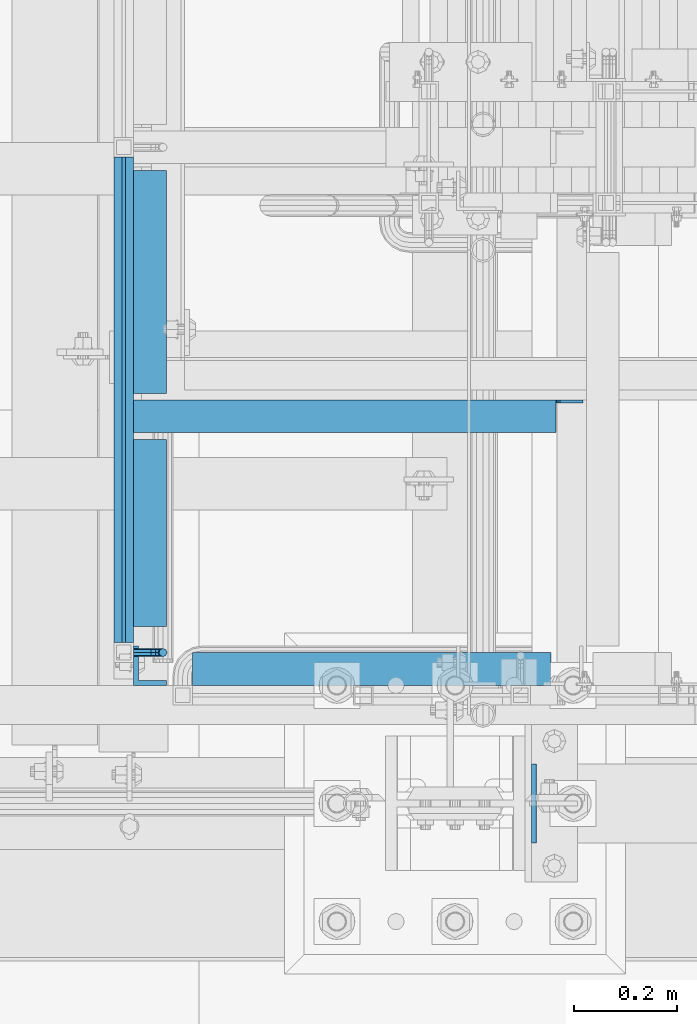
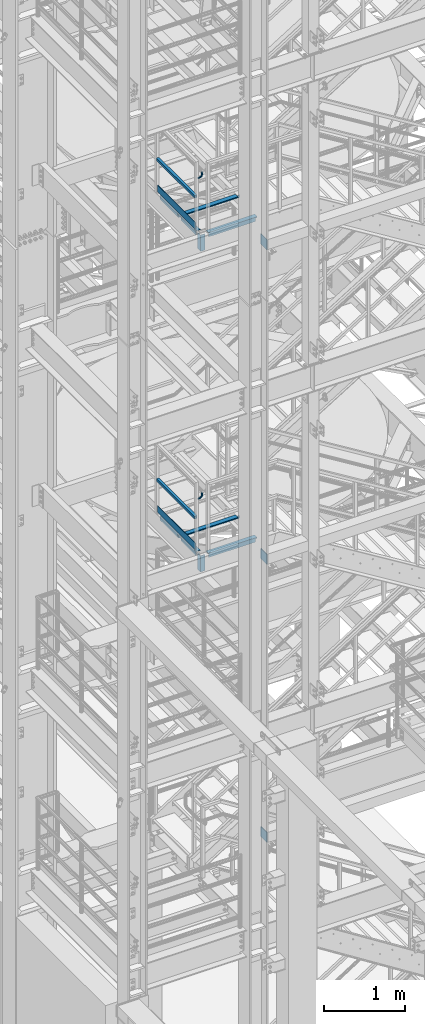
# One storey, part 1125 of 1876: 19 beams, 9 elements without a shape of their own.
"""IFC2X3 building model written with IfcOpenShell, lengths in millimetres."""

from ifc_helpers import new_model, si_unit, frame, origin_with_axes, place, context, subcontext, project, spatial, faceted_brep, material, type_object, element, aggregate, save


model = new_model("IFC2X3")

# Units and contexts
model_context = context("Model", 3, precision=1e-05, world=origin_with_axes())
body_context = subcontext(model_context, "Body", "Model", "MODEL_VIEW")
ifc_project = project(units=[si_unit("LENGTHUNIT", "METRE", prefix="MILLI"), si_unit("AREAUNIT", "SQUARE_METRE"), si_unit("VOLUMEUNIT", "CUBIC_METRE"), si_unit("MASSUNIT", "GRAM", prefix="KILO"), si_unit("TIMEUNIT", "SECOND"), si_unit("PLANEANGLEUNIT", "RADIAN"), si_unit("SOLIDANGLEUNIT", "STERADIAN"), si_unit("THERMODYNAMICTEMPERATUREUNIT", "DEGREE_CELSIUS"), si_unit("LUMINOUSINTENSITYUNIT", "LUMEN")], contexts=[model_context])

# Site, building, storey
site_placement = place(None, origin_with_axes())
site = spatial("IfcSite", under=ifc_project, at=site_placement, CompositionType="ELEMENT")
building_placement = place(site_placement, origin_with_axes())
building = spatial("IfcBuilding", under=site, at=building_placement, Name="Undefined", CompositionType="ELEMENT")
storey_placement = place(building_placement, origin_with_axes())
storey = spatial("IfcBuildingStorey", under=building, at=storey_placement, Name="Undefined", CompositionType="ELEMENT", Elevation=0.0)

# Assembly, beam
assembly_1_placement = place(storey_placement, origin_with_axes())
assembly_1 = element("IfcElementAssembly", 1, at=assembly_1_placement, inside=storey, Name="FRAME", AssemblyPlace="NOTDEFINED", PredefinedType="RIGID_FRAME")
ifc_material_1 = material(Name="STEEL/A36")
beam_type_1 = type_object("IfcBeamType", PredefinedType="NOTDEFINED")
beam_1_placement = place(assembly_1_placement, frame((1879.58075726968, -7188.2, 6407.15001063848), z_axis=(0.0, 0.0, 1.0), x_axis=(0.0, 1.0, 0.0)))
beam_1 = element("IfcBeam", 2, at=beam_1_placement, type_object=beam_type_1, material=ifc_material_1, Name="PLATE", context=body_context, shape_type="Brep", body=[
    faceted_brep([(0.0, 4.76249999999982, -76.1999999999998), (3.63797880709171e-12, 4.76249999999982, 76.1999969482422), (152.399993896484, 4.76250000000073, 76.1999969482422), (152.4, 4.76249999999982, -76.1999999999998), (3.63797880709171e-12, -4.76249999999982, 76.1999969482422), (152.399993896484, -4.76250000000073, 76.1999969482422), (0.0, -4.76249999999982, -76.1999999999998), (152.4, -4.76249999999982, -76.1999999999998)], [[[0, 1, 2, 3]], [[4, 5, 2, 1]], [[4, 6, 7, 5]], [[6, 0, 3, 7]], [[5, 7, 3, 2]], [[6, 4, 1, 0]]]),
])
aggregate(assembly_1, [beam_1])

assembly_2_placement = place(storey_placement, origin_with_axes())
assembly_2 = element("IfcElementAssembly", 3, at=assembly_2_placement, inside=storey, Name="FRAME", AssemblyPlace="NOTDEFINED", PredefinedType="RIGID_FRAME")
beam_2_placement = place(assembly_2_placement, frame((1879.59999980926, -7188.2, 10598.15), z_axis=(0.0, 0.0, 1.0), x_axis=(0.0, 1.0, 0.0)))
beam_2 = element("IfcBeam", 4, at=beam_2_placement, type_object=beam_type_1, material=ifc_material_1, Name="PLATE", context=body_context, shape_type="Brep", body=[
    faceted_brep([(0.0, 4.76249999999982, -76.1999999999998), (3.63797880709171e-12, 4.76249999999982, 76.1999969482422), (152.399993896484, 4.76250000000073, 76.1999969482422), (152.4, 4.76249999999982, -76.1999999999998), (3.63797880709171e-12, -4.76249999999982, 76.1999969482422), (152.399993896484, -4.76250000000073, 76.1999969482422), (0.0, -4.76249999999982, -76.1999999999998), (152.4, -4.76249999999982, -76.1999999999998)], [[[0, 1, 2, 3]], [[4, 5, 2, 1]], [[4, 6, 7, 5]], [[6, 0, 3, 7]], [[5, 7, 3, 2]], [[6, 4, 1, 0]]]),
])
aggregate(assembly_2, [beam_2])

assembly_3_placement = place(storey_placement, origin_with_axes())
assembly_3 = element("IfcElementAssembly", 5, at=assembly_3_placement, inside=storey, Name="FRAME", AssemblyPlace="NOTDEFINED", PredefinedType="RIGID_FRAME")
beam_3_placement = place(assembly_3_placement, frame((1879.59999980926, -7188.2, 15335.25), z_axis=(0.0, 0.0, 1.0), x_axis=(0.0, 1.0, 0.0)))
beam_3 = element("IfcBeam", 6, at=beam_3_placement, type_object=beam_type_1, material=ifc_material_1, Name="PLATE", context=body_context, shape_type="Brep", body=[
    faceted_brep([(0.0, 4.76249999999982, -76.1999999999998), (3.63797880709171e-12, 4.76249999999982, 76.1999969482422), (152.399993896484, 4.76250000000073, 76.1999969482422), (152.4, 4.76249999999982, -76.1999999999998), (3.63797880709171e-12, -4.76249999999982, 76.1999969482422), (152.399993896484, -4.76250000000073, 76.1999969482422), (0.0, -4.76249999999982, -76.1999999999998), (152.4, -4.76249999999982, -76.1999999999998)], [[[0, 1, 2, 3]], [[4, 5, 2, 1]], [[4, 6, 7, 5]], [[6, 0, 3, 7]], [[5, 7, 3, 2]], [[6, 4, 1, 0]]]),
])
aggregate(assembly_3, [beam_3])

# Assembly, beams
assembly_4_placement = place(storey_placement, origin_with_axes())
assembly_4 = element("IfcElementAssembly", 7, at=assembly_4_placement, inside=storey, Name="STRINGER", AssemblyPlace="NOTDEFINED", PredefinedType="RIGID_FRAME")
beam_type_2 = type_object("IfcBeamType", Name="L2-1/2X2-1/2X1/4", PredefinedType="NOTDEFINED")
beam_4_placement = place(assembly_4_placement, frame((1136.64999924824, -6769.10000137764, 15531.2768517499), z_axis=(1.0, 0.0, 0.0), x_axis=(0.0, 1.0, 0.0)))
beam_4 = element("IfcBeam", 8, at=beam_4_placement, type_object=beam_type_2, material=ifc_material_1, Name="ANGLE", ObjectType="L2-1/2X2-1/2X1/4", context=body_context, shape_type="Brep", body=[
    faceted_brep([(0.0, 31.75, -31.75), (0.0, 31.75, 31.75), (361.950002661927, 31.75, 31.7499999999923), (361.950002661926, 31.75, -31.7500000000077), (0.0, 25.3999999999996, 31.75), (361.950002661927, 25.3999999999996, 31.7499999999923), (0.0, 25.3999999999996, -25.3999999999996), (361.950002661926, 25.3999999999996, -25.4000000000076), (0.0, -31.75, -25.3999999999996), (361.950002661926, -31.75, -25.4000000000076), (0.0, -31.75, -31.75), (361.950002661926, -31.75, -31.7500000000077)], [[[0, 1, 2, 3]], [[1, 4, 5, 2]], [[4, 6, 7, 5]], [[6, 8, 9, 7]], [[8, 10, 11, 9]], [[10, 0, 3, 11]], [[5, 7, 9, 11, 3, 2]], [[10, 8, 6, 4, 1, 0]]]),
])
beam_5_placement = place(assembly_4_placement, frame((1136.65000017996, -6318.25000169504, 15531.2768517499), z_axis=(1.0, 0.0, 0.0), x_axis=(0.0, 1.0, 0.0)))
beam_5 = element("IfcBeam", 9, at=beam_5_placement, type_object=beam_type_2, material=ifc_material_1, Name="ANGLE", ObjectType="L2-1/2X2-1/2X1/4", context=body_context, shape_type="Brep", body=[
    faceted_brep([(0.0, 31.75, -31.75), (0.0, 31.75, 31.75), (431.800000762049, 31.75, 31.75), (431.800000762049, 31.75, -31.75), (0.0, 25.3999999999996, 31.75), (431.800000762049, 25.3999999999996, 31.75), (0.0, 25.3999999999996, -25.3999999999996), (431.800000762049, 25.3999999999996, -25.4000000000001), (0.0, -31.75, -25.3999999999996), (431.800000762049, -31.75, -25.4000000000001), (0.0, -31.75, -31.75), (431.800000762049, -31.75, -31.75)], [[[0, 1, 2, 3]], [[1, 4, 5, 2]], [[4, 6, 7, 5]], [[6, 8, 9, 7]], [[8, 10, 11, 9]], [[10, 0, 3, 11]], [[5, 7, 9, 11, 3, 2]], [[10, 8, 6, 4, 1, 0]]]),
])

assembly_5_placement = place(storey_placement, origin_with_axes())
assembly_5 = element("IfcElementAssembly", 10, at=assembly_5_placement, inside=storey, Name="STRINGER", AssemblyPlace="NOTDEFINED", PredefinedType="RIGID_FRAME")
beam_6_placement = place(assembly_5_placement, frame((1136.64999959676, -6769.10000137713, 10702.925), z_axis=(1.0, 0.0, 0.0), x_axis=(0.0, 1.0, 0.0)))
beam_6 = element("IfcBeam", 11, at=beam_6_placement, type_object=beam_type_2, material=ifc_material_1, Name="ANGLE", ObjectType="L2-1/2X2-1/2X1/4", context=body_context, shape_type="Brep", body=[
    faceted_brep([(0.0, 31.75, -31.75), (0.0, 31.75, 31.75), (361.950002661927, 31.75, 31.7499999999923), (361.950002661926, 31.75, -31.7500000000077), (0.0, 25.3999999999996, 31.75), (361.950002661927, 25.3999999999996, 31.7499999999923), (0.0, 25.3999999999996, -25.3999999999996), (361.950002661926, 25.3999999999996, -25.4000000000076), (0.0, -31.75, -25.3999999999996), (361.950002661926, -31.75, -25.4000000000076), (0.0, -31.75, -31.75), (361.950002661926, -31.75, -31.7500000000077)], [[[0, 1, 2, 3]], [[1, 4, 5, 2]], [[4, 6, 7, 5]], [[6, 8, 9, 7]], [[8, 10, 11, 9]], [[10, 0, 3, 11]], [[5, 7, 9, 11, 3, 2]], [[10, 8, 6, 4, 1, 0]]]),
])
beam_7_placement = place(assembly_5_placement, frame((1136.65000052848, -6318.25000169453, 10702.925), z_axis=(1.0, 0.0, 0.0), x_axis=(0.0, 1.0, 0.0)))
beam_7 = element("IfcBeam", 12, at=beam_7_placement, type_object=beam_type_2, material=ifc_material_1, Name="ANGLE", ObjectType="L2-1/2X2-1/2X1/4", context=body_context, shape_type="Brep", body=[
    faceted_brep([(0.0, 31.75, -31.75), (0.0, 31.75, 31.75), (431.800000762049, 31.75, 31.75), (431.800000762049, 31.75, -31.75), (0.0, 25.3999999999996, 31.75), (431.800000762049, 25.3999999999996, 31.75), (0.0, 25.3999999999996, -25.3999999999996), (431.800000762049, 25.3999999999996, -25.4000000000001), (0.0, -31.75, -25.3999999999996), (431.800000762049, -31.75, -25.4000000000001), (0.0, -31.75, -31.75), (431.800000762049, -31.75, -31.75)], [[[0, 1, 2, 3]], [[1, 4, 5, 2]], [[4, 6, 7, 5]], [[6, 8, 9, 7]], [[8, 10, 11, 9]], [[10, 0, 3, 11]], [[5, 7, 9, 11, 3, 2]], [[10, 8, 6, 4, 1, 0]]]),
])

# Beam
beam_8_placement = place(assembly_4_placement, frame((1104.89999999374, -6362.70000114803, 15531.3367795925), z_axis=(0.0, -1.0, 0.0), x_axis=(1.0, 0.0, 0.0)))
beam_8 = element("IfcBeam", 13, at=beam_8_placement, type_object=beam_type_2, material=ifc_material_1, Name="STRINGER", ObjectType="L2-1/2X2-1/2X1/4", context=body_context, shape_type="Brep", body=[
    faceted_brep([(0.0, -31.75, -31.75), (0.0, -31.75, -25.3999999999996), (0.0, 25.3999999999996, -25.3999999999996), (0.0, 25.3999999999996, 31.75), (0.0, 31.75, 31.75), (0.0, 31.75, -31.75), (869.950004852295, 6.34999909336329, -25.3999999999996), (830.262999809266, 6.34999909336329, -25.3999999999996), (825.40292029122, 7.31672901595084, -25.3999999999996), (821.282743823066, 10.0697429164284, -25.3999999999996), (818.529729922588, 14.189919384582, -25.3999999999996), (817.563000000001, 19.0499989026284, -25.3999999999996), (817.563000000001, 25.3999999999996, -25.3999999999996), (869.949999999999, -31.75, -25.3999999999996), (869.950004852295, -19.0499986178183, -25.3999999999996), (817.563000000001, 25.3999999999996, 31.75), (817.563000000001, 31.75, 31.75), (817.563000000001, 31.75, -31.75), (817.563000000001, 19.0499989026284, -31.75), (818.529729922588, 14.189919384582, -31.75), (821.282743823066, 10.0697429164284, -31.75), (825.40292029122, 7.31672901595084, -31.75), (830.262999809266, 6.34999909336329, -31.75), (869.950004852295, 6.34999909336329, -31.75), (869.950004852295, -19.0499986178183, -31.75), (869.949999999999, -31.75, -31.75)], [[[0, 1, 2, 3, 4, 5]], [[6, 7, 8, 9, 10, 11, 12, 2, 1, 13, 14]], [[3, 2, 12, 15]], [[4, 3, 15, 16]], [[5, 4, 16, 17]], [[15, 12, 11, 18, 17, 16]], [[10, 19, 18, 11]], [[9, 20, 19, 10]], [[8, 21, 20, 9]], [[7, 22, 21, 8]], [[6, 23, 22, 7]], [[14, 24, 23, 6]], [[0, 5, 17, 18, 19, 20, 21, 22, 23, 24, 25]], [[1, 0, 25, 13]], [[24, 14, 13, 25]]]),
])

aggregate(assembly_4, [beam_4, beam_5, beam_8])

# Assembly, beam
assembly_6_placement = place(storey_placement, origin_with_axes())
assembly_6 = element("IfcElementAssembly", 14, at=assembly_6_placement, inside=storey, Name="STRINGER", AssemblyPlace="NOTDEFINED", PredefinedType="RIGID_FRAME")
beam_9_placement = place(assembly_6_placement, frame((1995.4875, -6851.65000114876, 15531.2768518519), z_axis=(0.0, 1.0, 0.0), x_axis=(-1.0, 0.0, 0.0)))
beam_9 = element("IfcBeam", 15, at=beam_9_placement, type_object=beam_type_2, material=ifc_material_1, Name="ANGLE", ObjectType="L2-1/2X2-1/2X1/4", context=body_context, shape_type="Brep", body=[
    faceted_brep([(82.5500000000022, 19.0499999999556, -25.3999999999996), (82.5500000000022, 19.0499996253002, -31.75), (107.950000724835, 19.0499996252966, -31.75), (107.950000724835, 19.049999999952, -25.3999999999996), (107.950000724835, -31.7499992371049, -25.3999999999996), (107.950000724835, -31.75, -31.75), (82.5500000000022, 25.3999999999996, 31.75), (82.5500000000022, 25.3999999999996, -25.3999999999996), (776.287500000002, 25.3999999999996, -25.3999999999996), (776.287500000002, 25.3999999999996, 31.75), (82.5500000000022, 31.75, 31.75), (776.287500000002, 31.75, 31.75), (82.5500000000022, 31.75, -31.75), (776.287500000002, 31.75, -31.75), (776.287500000002, -31.75, -25.3999999999996), (776.287500000002, -31.75, -31.75)], [[[0, 1, 2, 3]], [[4, 3, 2, 5]], [[6, 7, 8, 9]], [[10, 6, 9, 11]], [[12, 10, 11, 13]], [[9, 8, 14, 15, 13, 11]], [[15, 14, 4, 5]], [[1, 12, 13, 15, 5, 2]], [[7, 6, 10, 12, 1, 0]], [[14, 8, 7, 0, 3, 4]]]),
])

# Beam
beam_10_placement = place(assembly_5_placement, frame((1104.90000034225, -6362.70000114753, 10702.9250004311), z_axis=(0.0, -1.0, 0.0), x_axis=(1.0, 0.0, 0.0)))
beam_10 = element("IfcBeam", 16, at=beam_10_placement, type_object=beam_type_2, material=ifc_material_1, Name="STRINGER", ObjectType="L2-1/2X2-1/2X1/4", context=body_context, shape_type="Brep", body=[
    faceted_brep([(0.0, -31.75, -31.75), (0.0, -31.75, -25.3999999999996), (0.0, 25.3999999999996, -25.3999999999996), (0.0, 25.3999999999996, 31.75), (0.0, 31.75, 31.75), (0.0, 31.75, -31.75), (869.950004852295, 6.34999909336329, -25.3999999999996), (830.262999809266, 6.34999909336329, -25.3999999999996), (825.40292029122, 7.31672901595084, -25.3999999999996), (821.282743823066, 10.0697429164284, -25.3999999999996), (818.529729922588, 14.189919384582, -25.3999999999996), (817.563000000001, 19.0499989026284, -25.3999999999996), (817.563000000001, 25.3999999999996, -25.3999999999996), (869.949999999999, -31.75, -25.3999999999996), (869.950004852295, -19.0499986178183, -25.3999999999996), (817.563000000001, 25.3999999999996, 31.75), (817.563000000001, 31.75, 31.75), (817.563000000001, 31.75, -31.75), (817.563000000001, 19.0499989026284, -31.75), (818.529729922588, 14.189919384582, -31.75), (821.282743823066, 10.0697429164284, -31.75), (825.40292029122, 7.31672901595084, -31.75), (830.262999809266, 6.34999909336329, -31.75), (869.950004852295, 6.34999909336329, -31.75), (869.950004852295, -19.0499986178183, -31.75), (869.949999999999, -31.75, -31.75)], [[[0, 1, 2, 3, 4, 5]], [[6, 7, 8, 9, 10, 11, 12, 2, 1, 13, 14]], [[3, 2, 12, 15]], [[4, 3, 15, 16]], [[5, 4, 16, 17]], [[15, 12, 11, 18, 17, 16]], [[10, 19, 18, 11]], [[9, 20, 19, 10]], [[8, 21, 20, 9]], [[7, 22, 21, 8]], [[6, 23, 22, 7]], [[14, 24, 23, 6]], [[0, 5, 17, 18, 19, 20, 21, 22, 23, 24, 25]], [[1, 0, 25, 13]], [[24, 14, 13, 25]]]),
])

aggregate(assembly_5, [beam_6, beam_7, beam_10])

# Assembly, beam
assembly_7_placement = place(storey_placement, origin_with_axes())
assembly_7 = element("IfcElementAssembly", 17, at=assembly_7_placement, inside=storey, Name="STRINGER", AssemblyPlace="NOTDEFINED", PredefinedType="RIGID_FRAME")
beam_11_placement = place(assembly_7_placement, frame((1995.48750034226, -6851.65000114826, 10702.925), z_axis=(0.0, 1.0, 0.0), x_axis=(-1.0, 0.0, 0.0)))
beam_11 = element("IfcBeam", 18, at=beam_11_placement, type_object=beam_type_2, material=ifc_material_1, Name="ANGLE", ObjectType="L2-1/2X2-1/2X1/4", context=body_context, shape_type="Brep", body=[
    faceted_brep([(82.5500000000022, 19.0499999999556, -25.3999999999996), (82.5500000000022, 19.0499996253002, -31.75), (107.950000724835, 19.0499996252966, -31.75), (107.950000724835, 19.049999999952, -25.3999999999996), (107.950000724835, -31.7499992371049, -25.3999999999996), (107.950000724835, -31.75, -31.75), (82.5500000000022, 25.3999999999996, 31.75), (82.5500000000022, 25.3999999999996, -25.3999999999996), (776.287500000002, 25.3999999999996, -25.3999999999996), (776.287500000002, 25.3999999999996, 31.75), (82.5500000000022, 31.75, 31.75), (776.287500000002, 31.75, 31.75), (82.5500000000022, 31.75, -31.75), (776.287500000002, 31.75, -31.75), (776.287500000002, -31.75, -25.3999999999996), (776.287500000002, -31.75, -31.75)], [[[0, 1, 2, 3]], [[4, 3, 2, 5]], [[6, 7, 8, 9]], [[10, 6, 9, 11]], [[12, 10, 11, 13]], [[9, 8, 14, 15, 13, 11]], [[15, 14, 4, 5]], [[1, 12, 13, 15, 5, 2]], [[7, 6, 10, 12, 1, 0]], [[14, 8, 7, 0, 3, 4]]]),
])

assembly_8_placement = place(storey_placement, origin_with_axes())
assembly_8 = element("IfcElementAssembly", 19, at=assembly_8_placement, inside=storey, Name="RAIL", AssemblyPlace="NOTDEFINED", PredefinedType="RIGID_FRAME")
beam_type_3 = type_object("IfcBeamType", PredefinedType="NOTDEFINED")
beam_12_placement = place(assembly_8_placement, frame((1085.84999999373, -6800.85000191376, 15658.2768517481), z_axis=(0.0, 0.0, 1.0), x_axis=(0.0, 1.0, 0.0)))
beam_12 = element("IfcBeam", 20, at=beam_12_placement, type_object=beam_type_3, material=ifc_material_1, Name="PLATE", context=body_context, shape_type="Brep", body=[
    faceted_brep([(0.0, 3.17500000000018, -50.8000000000002), (0.0, 3.17500000000018, 50.8000000000002), (939.800001531449, 3.17499999999995, 50.7999999999993), (939.800001531449, 3.17499999999995, -50.7999999999993), (0.0, -3.17500000000018, 50.8000000000002), (939.800001531449, -3.17499999999995, 50.7999999999993), (0.0, -3.17500000000018, -50.8000000000002), (939.800001531449, -3.17499999999995, -50.7999999999993)], [[[0, 1, 2, 3]], [[1, 4, 5, 2]], [[4, 6, 7, 5]], [[6, 0, 3, 7]], [[5, 7, 3, 2]], [[6, 4, 1, 0]]]),
])

# Assembly, beams
assembly_9_placement = place(storey_placement, origin_with_axes())
assembly_9 = element("IfcElementAssembly", 21, at=assembly_9_placement, inside=storey, Name="RAIL", AssemblyPlace="NOTDEFINED", PredefinedType="RIGID_FRAME")
beam_13_placement = place(assembly_9_placement, frame((1085.85000034225, -6800.85000191326, 10829.9249999981), z_axis=(0.0, 0.0, 1.0), x_axis=(0.0, 1.0, 0.0)))
beam_13 = element("IfcBeam", 22, at=beam_13_placement, type_object=beam_type_3, material=ifc_material_1, Name="PLATE", context=body_context, shape_type="Brep", body=[
    faceted_brep([(0.0, 3.17500000000018, -50.8000000000002), (0.0, 3.17500000000018, 50.8000000000002), (939.800001531449, 3.17499999999995, 50.7999999999993), (939.800001531449, 3.17499999999995, -50.7999999999993), (0.0, -3.17500000000018, 50.8000000000002), (939.800001531449, -3.17499999999995, 50.7999999999993), (0.0, -3.17500000000018, -50.8000000000002), (939.800001531449, -3.17499999999995, -50.7999999999993)], [[[0, 1, 2, 3]], [[1, 4, 5, 2]], [[4, 6, 7, 5]], [[6, 0, 3, 7]], [[5, 7, 3, 2]], [[6, 4, 1, 0]]]),
])
ifc_material_2 = material()
beam_type_4 = type_object("IfcBeamType", Name="HSS1-1/2X1-1/2X1/8", PredefinedType="NOTDEFINED")
beam_14_placement = place(assembly_9_placement, frame((1085.85000034225, -5842.00000114681, 11274.4249999981), z_axis=(0.0, 0.0, 1.0), x_axis=(0.0, -1.0, 0.0)))
beam_14 = element("IfcBeam", 23, at=beam_14_placement, type_object=beam_type_4, material=ifc_material_2, Name="RAIL", ObjectType="HSS1-1/2X1-1/2X1/8", context=body_context, shape_type="Brep", body=[
    faceted_brep([(19.0500000000002, -19.0499992349996, 19.0499992350001), (19.0500000000002, 19.0499992349996, 19.0499992350001), (19.0500000000002, 19.0499992349996, -19.0499992350001), (19.0500000000002, -19.0499992349996, -19.0499992350001), (19.0500000000002, -15.8749992829999, 15.8749992829999), (19.0500000000002, -15.8749992829999, -15.8749992829999), (19.0500000000002, 15.8749992829999, -15.8749992829999), (19.0500000000002, 15.8749992829999, 15.8749992829999), (958.850000766446, 19.0499992350001, -19.0499992349996), (958.850000766446, -19.0499992350001, -19.0499992349996), (958.850000766446, -19.0499992350001, 19.0499992349996), (958.850000766446, 19.0499992350001, 19.0499992349996), (958.850000766446, -15.8749992830001, 15.8749992829999), (958.850000766446, 15.8749992830001, 15.8749992829999), (958.850000766446, 15.8749992830001, -15.8749992829999), (958.850000766446, -15.8749992830001, -15.8749992829999)], [[[0, 1, 2, 3], [4, 5, 6, 7]], [[8, 9, 3, 2]], [[9, 10, 0, 3]], [[10, 11, 1, 0]], [[11, 8, 2, 1]], [[10, 9, 8, 11], [12, 13, 14, 15]], [[13, 12, 4, 7]], [[14, 13, 7, 6]], [[15, 14, 6, 5]], [[12, 15, 5, 4]]]),
])

# Beam
beam_15_placement = place(assembly_8_placement, frame((1085.84999999374, -5842.00000114732, 16102.7768517481), z_axis=(0.0, 0.0, 1.0), x_axis=(0.0, -1.0, 0.0)))
beam_15 = element("IfcBeam", 24, at=beam_15_placement, type_object=beam_type_4, material=ifc_material_2, Name="RAIL", ObjectType="HSS1-1/2X1-1/2X1/8", context=body_context, shape_type="Brep", body=[
    faceted_brep([(19.0500000000002, -19.0499992349996, 19.0499992350001), (19.0500000000002, 19.0499992349996, 19.0499992350001), (19.0500000000002, 19.0499992349996, -19.0499992350001), (19.0500000000002, -19.0499992349996, -19.0499992350001), (19.0500000000002, -15.8749992829999, 15.8749992829999), (19.0500000000002, -15.8749992829999, -15.8749992829999), (19.0500000000002, 15.8749992829999, -15.8749992829999), (19.0500000000002, 15.8749992829999, 15.8749992829999), (958.850000766446, 19.0499992350001, -19.0499992349996), (958.850000766446, -19.0499992350001, -19.0499992349996), (958.850000766446, -19.0499992350001, 19.0499992349996), (958.850000766446, 19.0499992350001, 19.0499992349996), (958.850000766446, -15.8749992830001, 15.8749992829999), (958.850000766446, 15.8749992830001, 15.8749992829999), (958.850000766446, 15.8749992830001, -15.8749992829999), (958.850000766446, -15.8749992830001, -15.8749992829999)], [[[0, 1, 2, 3], [4, 5, 6, 7]], [[8, 9, 3, 2]], [[9, 10, 0, 3]], [[10, 11, 1, 0]], [[11, 8, 2, 1]], [[10, 9, 8, 11], [12, 13, 14, 15]], [[13, 12, 4, 7]], [[14, 13, 7, 6]], [[15, 14, 6, 5]], [[12, 15, 5, 4]]]),
])

beam_type_5 = type_object("IfcBeamType", PredefinedType="NOTDEFINED")
beam_16_placement = place(assembly_8_placement, frame((1104.89999922875, -6819.90000191376, 16388.4316082526), z_axis=(0.0, -1.0, 0.0), x_axis=(1.0, 0.0, 0.0)))
beam_16 = element("IfcBeam", 25, at=beam_16_placement, type_object=beam_type_5, material=ifc_material_1, Name="BRACKET", context=body_context, shape_type="Brep", body=[
    faceted_brep([(0.0, -7.9375, 0.0), (0.0, -5.61266007566822, -5.61266007566883), (23.8125, -5.61266007566883, -5.61266007566792), (23.8125, -7.9375, 0.0), (0.0, 0.0, -7.9375), (23.8125, 0.0, -7.9375), (0.0, 5.61266007566822, -5.61266007566883), (23.8125, 5.61266007566883, -5.61266007566792), (0.0, 7.9375, 0.0), (23.8125, 7.9375, 0.0), (0.0, 5.61266007566822, 5.61266007566883), (23.8125, 5.61266007566883, 5.61266007566792), (0.0, 0.0, 7.9375), (23.8125, 0.0, 7.9375), (0.0, -5.61266007566822, 5.61266007566883), (23.8125, -5.61266007566883, 5.61266007566792), (39.6077592547981, -4.79562758825341, 0.0), (38.7180815328556, -2.64775556579843, 5.61266007566792), (36.5702095103998, 2.53766620105671, 7.9375), (34.4223374879448, 7.72308796790821, 5.61266007566792), (33.5326597660023, 9.87095999036319, 0.0), (34.4223374879448, 7.72308796790821, -5.61266007566792), (36.5702095103998, 2.53766620105671, -7.9375), (38.7180815328556, -2.64775556579843, -5.61266007566792), (51.3544233967659, 5.79557812911298, -5.61266007566792), (52.9983334724348, 4.15166805344415, 0.0), (47.3856733967659, 9.76432812911298, -7.9375), (43.4169233967659, 13.733078129113, -5.61266007566792), (41.773013321098, 15.3769882047818, 0.0), (43.4169233967659, 13.733078129113, 5.61266007566792), (47.3856733967659, 9.76432812911298, 7.9375), (51.3544233967659, 5.79557812911298, 5.61266007566792), (59.7977570916764, 18.4319199930251, -5.61266007566792), (61.9456291141314, 17.5422422710835, 0.0), (54.6123353248231, 20.5797920154801, -7.9375), (49.4269135579698, 22.727664037935, -5.61266007566792), (47.2790415355148, 23.6173417598766, 0.0), (49.4269135579698, 22.727664037935, 5.61266007566792), (54.6123353248231, 20.5797920154801, 7.9375), (59.7977570916764, 18.4319199930251, 5.61266007566792), (62.7626616015468, 33.3375015258789, -5.61266007566792), (65.0875015258789, 33.3375015258789, 0.0), (57.1500015258789, 33.3375015258789, -7.9375), (51.5373414502101, 33.3375015258789, -5.61266007566792), (49.2125015258789, 33.3375015258789, 0.0), (51.5373414502101, 33.3375015258789, 5.61266007566792), (57.1500015258789, 33.3375015258789, 7.9375), (62.7626616015468, 33.3375015258789, 5.61266007566792), (62.7626616015468, 76.1999969482422, -5.61266007566792), (65.0875015258789, 76.1999969482422, 0.0), (57.1500015258789, 76.1999969482422, -7.9375), (51.537341450211, 76.1999969482422, -5.61266007566792), (49.2125015258789, 76.1999969482422, 0.0), (51.537341450211, 76.1999969482422, 5.61266007566792), (57.1500015258789, 76.1999969482422, 7.9375), (62.7626616015468, 76.1999969482422, 5.61266007566792)], [[[0, 1, 2, 3]], [[1, 4, 5, 2]], [[4, 6, 7, 5]], [[6, 8, 9, 7]], [[8, 10, 11, 9]], [[10, 12, 13, 11]], [[12, 14, 15, 13]], [[14, 0, 3, 15]], [[14, 12, 10, 8, 6, 4, 1, 0]], [[15, 3, 16, 17]], [[13, 15, 17, 18]], [[11, 13, 18, 19]], [[9, 11, 19, 20]], [[7, 9, 20, 21]], [[5, 7, 21, 22]], [[2, 5, 22, 23]], [[3, 2, 23, 16]], [[23, 24, 25, 16]], [[22, 26, 24, 23]], [[21, 27, 26, 22]], [[20, 28, 27, 21]], [[19, 29, 28, 20]], [[18, 30, 29, 19]], [[17, 31, 30, 18]], [[16, 25, 31, 17]], [[24, 32, 33, 25]], [[26, 34, 32, 24]], [[27, 35, 34, 26]], [[28, 36, 35, 27]], [[29, 37, 36, 28]], [[30, 38, 37, 29]], [[31, 39, 38, 30]], [[25, 33, 39, 31]], [[32, 40, 41, 33]], [[34, 42, 40, 32]], [[35, 43, 42, 34]], [[36, 44, 43, 35]], [[37, 45, 44, 36]], [[38, 46, 45, 37]], [[39, 47, 46, 38]], [[33, 41, 47, 39]], [[41, 40, 48, 49]], [[40, 42, 50, 48]], [[42, 43, 51, 50]], [[43, 44, 52, 51]], [[44, 45, 53, 52]], [[45, 46, 54, 53]], [[46, 47, 55, 54]], [[47, 41, 49, 55]], [[50, 51, 52, 53, 54, 55, 49, 48]]]),
])

aggregate(assembly_8, [beam_16, beam_12, beam_15])

beam_17_placement = place(assembly_9_placement, frame((1104.89999957726, -6819.90000191326, 11560.0797565027), z_axis=(0.0, -1.0, 0.0), x_axis=(1.0, 0.0, 0.0)))
beam_17 = element("IfcBeam", 26, at=beam_17_placement, type_object=beam_type_5, material=ifc_material_1, Name="BRACKET", context=body_context, shape_type="Brep", body=[
    faceted_brep([(0.0, -7.9375, 0.0), (0.0, -5.61266007566822, -5.61266007566883), (23.8125, -5.61266007566883, -5.61266007566792), (23.8125, -7.9375, 0.0), (0.0, 0.0, -7.9375), (23.8125, 0.0, -7.9375), (0.0, 5.61266007566822, -5.61266007566883), (23.8125, 5.61266007566883, -5.61266007566792), (0.0, 7.9375, 0.0), (23.8125, 7.9375, 0.0), (0.0, 5.61266007566822, 5.61266007566883), (23.8125, 5.61266007566883, 5.61266007566792), (0.0, 0.0, 7.9375), (23.8125, 0.0, 7.9375), (0.0, -5.61266007566822, 5.61266007566883), (23.8125, -5.61266007566883, 5.61266007566792), (39.6077592547981, -4.79562758825341, 0.0), (38.7180815328556, -2.64775556579843, 5.61266007566792), (36.5702095103998, 2.53766620105671, 7.9375), (34.4223374879448, 7.72308796790821, 5.61266007566792), (33.5326597660023, 9.87095999036319, 0.0), (34.4223374879448, 7.72308796790821, -5.61266007566792), (36.5702095103998, 2.53766620105671, -7.9375), (38.7180815328556, -2.64775556579843, -5.61266007566792), (51.3544233967659, 5.79557812911298, -5.61266007566792), (52.9983334724348, 4.15166805344415, 0.0), (47.3856733967659, 9.76432812911298, -7.9375), (43.4169233967659, 13.733078129113, -5.61266007566792), (41.773013321098, 15.3769882047818, 0.0), (43.4169233967659, 13.733078129113, 5.61266007566792), (47.3856733967659, 9.76432812911298, 7.9375), (51.3544233967659, 5.79557812911298, 5.61266007566792), (59.7977570916764, 18.4319199930251, -5.61266007566792), (61.9456291141314, 17.5422422710835, 0.0), (54.6123353248231, 20.5797920154801, -7.9375), (49.4269135579698, 22.727664037935, -5.61266007566792), (47.2790415355148, 23.6173417598766, 0.0), (49.4269135579698, 22.727664037935, 5.61266007566792), (54.6123353248231, 20.5797920154801, 7.9375), (59.7977570916764, 18.4319199930251, 5.61266007566792), (62.7626616015468, 33.3375015258789, -5.61266007566792), (65.0875015258789, 33.3375015258789, 0.0), (57.1500015258789, 33.3375015258789, -7.9375), (51.5373414502101, 33.3375015258789, -5.61266007566792), (49.2125015258789, 33.3375015258789, 0.0), (51.5373414502101, 33.3375015258789, 5.61266007566792), (57.1500015258789, 33.3375015258789, 7.9375), (62.7626616015468, 33.3375015258789, 5.61266007566792), (62.7626616015468, 76.1999969482422, -5.61266007566792), (65.0875015258789, 76.1999969482422, 0.0), (57.1500015258789, 76.1999969482422, -7.9375), (51.537341450211, 76.1999969482422, -5.61266007566792), (49.2125015258789, 76.1999969482422, 0.0), (51.537341450211, 76.1999969482422, 5.61266007566792), (57.1500015258789, 76.1999969482422, 7.9375), (62.7626616015468, 76.1999969482422, 5.61266007566792)], [[[0, 1, 2, 3]], [[1, 4, 5, 2]], [[4, 6, 7, 5]], [[6, 8, 9, 7]], [[8, 10, 11, 9]], [[10, 12, 13, 11]], [[12, 14, 15, 13]], [[14, 0, 3, 15]], [[14, 12, 10, 8, 6, 4, 1, 0]], [[15, 3, 16, 17]], [[13, 15, 17, 18]], [[11, 13, 18, 19]], [[9, 11, 19, 20]], [[7, 9, 20, 21]], [[5, 7, 21, 22]], [[2, 5, 22, 23]], [[3, 2, 23, 16]], [[23, 24, 25, 16]], [[22, 26, 24, 23]], [[21, 27, 26, 22]], [[20, 28, 27, 21]], [[19, 29, 28, 20]], [[18, 30, 29, 19]], [[17, 31, 30, 18]], [[16, 25, 31, 17]], [[24, 32, 33, 25]], [[26, 34, 32, 24]], [[27, 35, 34, 26]], [[28, 36, 35, 27]], [[29, 37, 36, 28]], [[30, 38, 37, 29]], [[31, 39, 38, 30]], [[25, 33, 39, 31]], [[32, 40, 41, 33]], [[34, 42, 40, 32]], [[35, 43, 42, 34]], [[36, 44, 43, 35]], [[37, 45, 44, 36]], [[38, 46, 45, 37]], [[39, 47, 46, 38]], [[33, 41, 47, 39]], [[41, 40, 48, 49]], [[40, 42, 50, 48]], [[42, 43, 51, 50]], [[43, 44, 52, 51]], [[44, 45, 53, 52]], [[45, 46, 54, 53]], [[46, 47, 55, 54]], [[47, 41, 49, 55]], [[50, 51, 52, 53, 54, 55, 49, 48]]]),
])

aggregate(assembly_9, [beam_17, beam_13, beam_14])

beam_type_6 = type_object("IfcBeamType", Name="L3X2-1/2X3/8", PredefinedType="NOTDEFINED")
beam_18_placement = place(assembly_6_placement, frame((1136.65000038237, -6845.2999988948, 15562.262499997), z_axis=(0.0, 1.0, 0.0), x_axis=(0.0, 0.0, -1.0)))
beam_18 = element("IfcBeam", 27, at=beam_18_placement, type_object=beam_type_6, material=ifc_material_1, Name="ANGLE", ObjectType="L3X2-1/2X3/8", context=body_context, shape_type="Brep", body=[
    faceted_brep([(0.0, 31.75, -38.1000000000004), (0.0, 31.75, 38.1000000000004), (241.299999999999, 31.75, 38.1000000000004), (241.299999999999, 31.75, -38.1000000000004), (0.0, 22.2249999999999, 38.1000000000004), (241.299999999999, 22.2249999999999, 38.1000000000004), (0.0, 22.2249999999999, -28.5749999999998), (241.299999999999, 22.2249999999999, -28.5749999999998), (0.0, -31.75, -28.5749999999998), (241.299999999999, -31.75, -28.5749999999998), (0.0, -31.75, -38.1000000000004), (241.299999999999, -31.75, -38.1000000000004)], [[[0, 1, 2, 3]], [[1, 4, 5, 2]], [[4, 6, 7, 5]], [[6, 8, 9, 7]], [[8, 10, 11, 9]], [[10, 0, 3, 11]], [[5, 7, 9, 11, 3, 2]], [[10, 8, 6, 4, 1, 0]]]),
])

aggregate(assembly_6, [beam_18, beam_9])

beam_19_placement = place(assembly_7_placement, frame((1136.65000038237, -6845.2999988948, 10734.674999997), z_axis=(0.0, 1.0, 0.0), x_axis=(0.0, 0.0, -1.0)))
beam_19 = element("IfcBeam", 28, at=beam_19_placement, type_object=beam_type_6, material=ifc_material_1, Name="ANGLE", ObjectType="L3X2-1/2X3/8", context=body_context, shape_type="Brep", body=[
    faceted_brep([(0.0, 31.75, -38.1000000000004), (0.0, 31.75, 38.1000000000004), (241.299999999999, 31.75, 38.1000000000004), (241.299999999999, 31.75, -38.1000000000004), (0.0, 22.2249999999999, 38.1000000000004), (241.299999999999, 22.2249999999999, 38.1000000000004), (0.0, 22.2249999999999, -28.5749999999998), (241.299999999999, 22.2249999999999, -28.5749999999998), (0.0, -31.75, -28.5749999999998), (241.299999999999, -31.75, -28.5749999999998), (0.0, -31.75, -38.1000000000004), (241.299999999999, -31.75, -38.1000000000004)], [[[0, 1, 2, 3]], [[1, 4, 5, 2]], [[4, 6, 7, 5]], [[6, 8, 9, 7]], [[8, 10, 11, 9]], [[10, 0, 3, 11]], [[5, 7, 9, 11, 3, 2]], [[10, 8, 6, 4, 1, 0]]]),
])

aggregate(assembly_7, [beam_19, beam_11])

save(model, "model.ifc")
